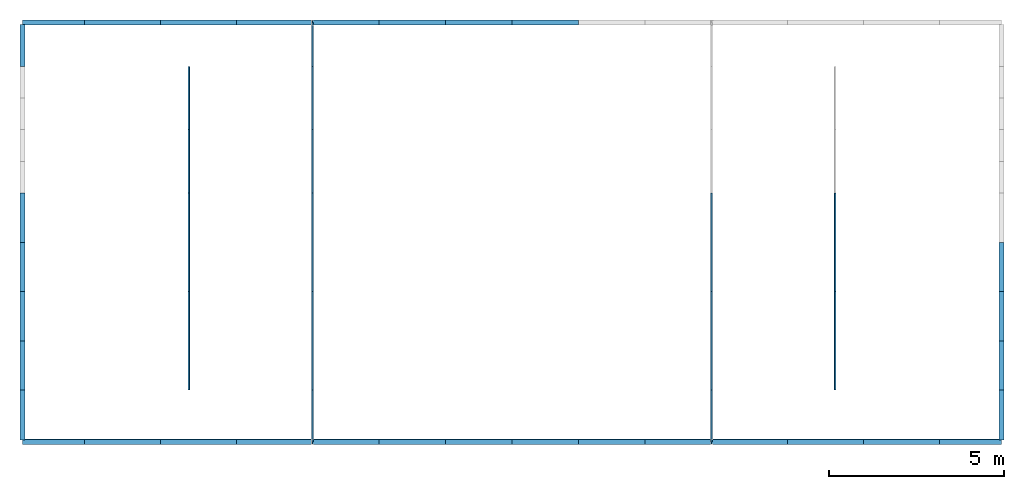
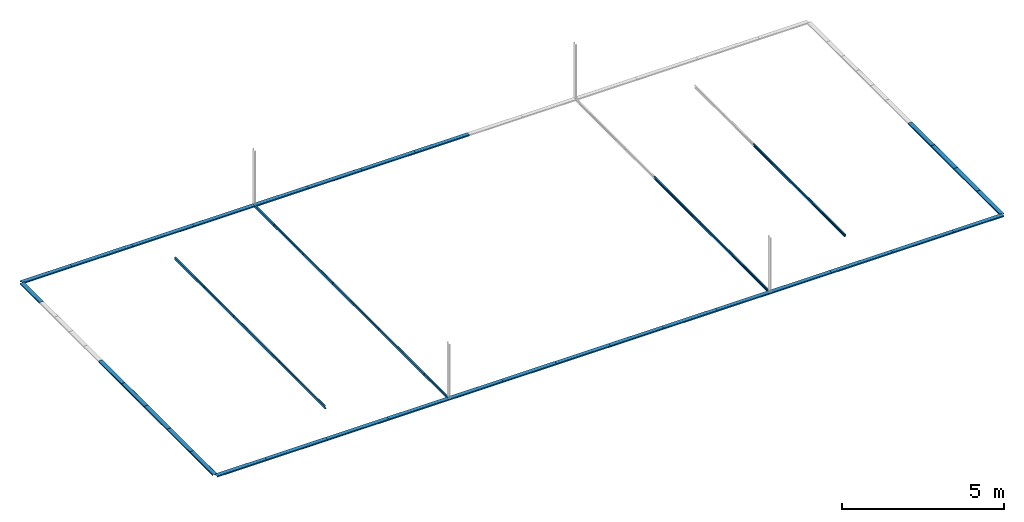
# One storey, part 3 of 4: 47 beams.
"""IFC4 building model written with IfcOpenShell, lengths in metres."""

from ifc_helpers import new_model, si_unit, derived_unit, frame, origin_with_axes, origin_2d_with_axis, place, context, project, spatial, c_section, extrude, material, material_profile, profile_set, profile_usage, element, save


model = new_model("IFC4")

# Units and contexts
model_context = context("Model", 3, world=origin_with_axes())
ifc_project = project(units=[si_unit("LENGTHUNIT", "METRE"), si_unit("AREAUNIT", "SQUARE_METRE"), si_unit("VOLUMEUNIT", "CUBIC_METRE"), derived_unit("SECTIONMODULUSUNIT", [(si_unit("LENGTHUNIT", "METRE"), 3)]), derived_unit("MOMENTOFINERTIAUNIT", [(si_unit("LENGTHUNIT", "METRE"), 4)]), si_unit("PLANEANGLEUNIT", "RADIAN"), si_unit("TIMEUNIT", "SECOND"), si_unit("THERMODYNAMICTEMPERATUREUNIT", "DEGREE_CELSIUS"), derived_unit("THERMALEXPANSIONCOEFFICIENTUNIT", [(si_unit("THERMODYNAMICTEMPERATUREUNIT", "DEGREE_CELSIUS"), -1)])], contexts=[model_context])

# Site, building, storey
site = spatial("IfcSite", under=ifc_project, CompositionType="ELEMENT")
building = spatial("IfcBuilding", under=site, Name="Building", CompositionType="ELEMENT")
storey = spatial("IfcBuildingStorey", under=building, Name="BASE LEVEL", CompositionType="ELEMENT", Elevation=7.8501)

# Beams
ifc_material = material(Name="SAE 1020")
ifc_material_profile_1 = material_profile(ifc_material, c_section(Depth=0.1, Width=0.05, WallThickness=0.003, Girth=0.017, InternalFilletRadius=0.003, at=origin_2d_with_axis()))
ifc_profile_set_1 = profile_set([ifc_material_profile_1])
ifc_profile_usage_1 = profile_usage(ifc_profile_set_1, cardinal=10)
beam_1_placement = place(None, frame((9.5343995, 8.75, 7.8501), z_axis=(3.3783784e-07, 1.0, -3.0405405e-05), x_axis=(0.9992562, 8.3491316e-07, 0.038562213)))
element("IfcBeam", 1, at=beam_1_placement, inside=storey, material=ifc_profile_usage_1, Name="1629", context=model_context, shape_type="SweptSolid", body=[
    extrude(c_section(Depth=0.1, Width=0.05, WallThickness=0.003, Girth=0.017, InternalFilletRadius=0.003, at=origin_2d_with_axis()), origin_with_axes(), (0.0, 0.0, 1.0), 1.48),
])
ifc_material_profile_2 = material_profile(ifc_material, c_section(Depth=0.1, Width=0.05, WallThickness=0.003, Girth=0.017, InternalFilletRadius=0.003, at=origin_2d_with_axis()))
ifc_profile_set_2 = profile_set([ifc_material_profile_2])
ifc_profile_usage_2 = profile_usage(ifc_profile_set_2, cardinal=10)
beam_2_placement = place(None, frame((9.5344, 10.23, 7.85), z_axis=(3.3783784e-07, 1.0, -3.0405405e-05), x_axis=(0.9992562, 8.3491316e-07, 0.038562213)))
element("IfcBeam", 2, at=beam_2_placement, inside=storey, material=ifc_profile_usage_2, Name="1630", context=model_context, shape_type="SweptSolid", body=[
    extrude(c_section(Depth=0.1, Width=0.05, WallThickness=0.003, Girth=0.017, InternalFilletRadius=0.003, at=origin_2d_with_axis()), origin_with_axes(), (0.0, 0.0, 1.0), 2.82),
])
ifc_material_profile_3 = material_profile(ifc_material, c_section(Depth=0.1, Width=0.05, WallThickness=0.003, Girth=0.017, InternalFilletRadius=0.003, at=origin_2d_with_axis()))
ifc_profile_set_3 = profile_set([ifc_material_profile_3])
ifc_profile_usage_3 = profile_usage(ifc_profile_set_3, cardinal=10)
beam_3_placement = place(None, frame((9.5344, 13.05, 7.85), z_axis=(3.3783784e-07, 1.0, -3.0405405e-05), x_axis=(0.9992562, 8.3491316e-07, 0.038562213)))
element("IfcBeam", 3, at=beam_3_placement, inside=storey, material=ifc_profile_usage_3, Name="1631", context=model_context, shape_type="SweptSolid", body=[
    extrude(c_section(Depth=0.1, Width=0.05, WallThickness=0.003, Girth=0.017, InternalFilletRadius=0.003, at=origin_2d_with_axis()), origin_with_axes(), (0.0, 0.0, 1.0), 2.82),
])
ifc_material_profile_4 = material_profile(ifc_material, c_section(Depth=0.1, Width=0.05, WallThickness=0.003, Girth=0.017, InternalFilletRadius=0.003, at=origin_2d_with_axis()))
ifc_profile_set_4 = profile_set([ifc_material_profile_4])
ifc_profile_usage_4 = profile_usage(ifc_profile_set_4, cardinal=10)
beam_4_placement = place(None, frame((9.5344, 15.87, 7.85), z_axis=(3.3783784e-07, 1.0, -3.0405405e-05), x_axis=(0.9992562, 8.3491316e-07, 0.038562213)))
element("IfcBeam", 4, at=beam_4_placement, inside=storey, material=ifc_profile_usage_4, Name="1632", context=model_context, shape_type="SweptSolid", body=[
    extrude(c_section(Depth=0.1, Width=0.05, WallThickness=0.003, Girth=0.017, InternalFilletRadius=0.003, at=origin_2d_with_axis()), origin_with_axes(), (0.0, 0.0, 1.0), 1.815),
])
ifc_material_profile_5 = material_profile(ifc_material, c_section(Depth=0.1, Width=0.05, WallThickness=0.003, Girth=0.017, InternalFilletRadius=0.003, at=origin_2d_with_axis()))
ifc_profile_set_5 = profile_set([ifc_material_profile_5])
ifc_profile_usage_5 = profile_usage(ifc_profile_set_5, cardinal=10)
beam_5_placement = place(None, frame((9.5344, 17.685, 7.85), z_axis=(3.3783784e-07, 1.0, -3.0405405e-05), x_axis=(0.9992562, 8.3491316e-07, 0.038562213)))
element("IfcBeam", 5, at=beam_5_placement, inside=storey, material=ifc_profile_usage_5, Name="1633", context=model_context, shape_type="SweptSolid", body=[
    extrude(c_section(Depth=0.1, Width=0.05, WallThickness=0.003, Girth=0.017, InternalFilletRadius=0.003, at=origin_2d_with_axis()), origin_with_axes(), (0.0, 0.0, 1.0), 1.815),
])
ifc_material_profile_6 = material_profile(ifc_material, c_section(Depth=0.1, Width=0.05, WallThickness=0.003, Girth=0.017, InternalFilletRadius=0.003, at=origin_2d_with_axis()))
ifc_profile_set_6 = profile_set([ifc_material_profile_6])
ifc_profile_usage_6 = profile_usage(ifc_profile_set_6, cardinal=10)
beam_6_placement = place(None, frame((9.5344, 19.5, 7.85), z_axis=(3.3783784e-07, 1.0, -3.0405405e-05), x_axis=(0.9992562, 8.3491316e-07, 0.038562213)))
element("IfcBeam", 6, at=beam_6_placement, inside=storey, material=ifc_profile_usage_6, Name="1634", context=model_context, shape_type="SweptSolid", body=[
    extrude(c_section(Depth=0.1, Width=0.05, WallThickness=0.003, Girth=0.017, InternalFilletRadius=0.003, at=origin_2d_with_axis()), origin_with_axes(), (0.0, 0.0, 1.0), 1.25),
])
ifc_material_profile_7 = material_profile(ifc_material, c_section(Depth=0.1, Width=0.05, WallThickness=0.003, Girth=0.017, InternalFilletRadius=0.003, at=origin_2d_with_axis()))
ifc_profile_set_7 = profile_set([ifc_material_profile_7])
ifc_profile_usage_7 = profile_usage(ifc_profile_set_7, cardinal=10)
beam_7_placement = place(None, frame((20.965601, 8.75, 7.8501), z_axis=(3.3783784e-07, 1.0, -3.0405405e-05), x_axis=(-0.9992562, 8.3491316e-07, 0.038562213)))
element("IfcBeam", 7, at=beam_7_placement, inside=storey, material=ifc_profile_usage_7, Name="1635", context=model_context, shape_type="SweptSolid", body=[
    extrude(c_section(Depth=0.1, Width=0.05, WallThickness=0.003, Girth=0.017, InternalFilletRadius=0.003, at=origin_2d_with_axis()), origin_with_axes(), (0.0, 0.0, 1.0), 1.48),
])
ifc_material_profile_8 = material_profile(ifc_material, c_section(Depth=0.1, Width=0.05, WallThickness=0.003, Girth=0.017, InternalFilletRadius=0.003, at=origin_2d_with_axis()))
ifc_profile_set_8 = profile_set([ifc_material_profile_8])
ifc_profile_usage_8 = profile_usage(ifc_profile_set_8, cardinal=10)
beam_8_placement = place(None, frame((20.9656, 10.23, 7.85), z_axis=(3.3783784e-07, 1.0, -3.0405405e-05), x_axis=(-0.9992562, 8.3491316e-07, 0.038562213)))
element("IfcBeam", 8, at=beam_8_placement, inside=storey, material=ifc_profile_usage_8, Name="1636", context=model_context, shape_type="SweptSolid", body=[
    extrude(c_section(Depth=0.1, Width=0.05, WallThickness=0.003, Girth=0.017, InternalFilletRadius=0.003, at=origin_2d_with_axis()), origin_with_axes(), (0.0, 0.0, 1.0), 2.82),
])
ifc_material_profile_9 = material_profile(ifc_material, c_section(Depth=0.1, Width=0.05, WallThickness=0.003, Girth=0.017, InternalFilletRadius=0.003, at=origin_2d_with_axis()))
ifc_profile_set_9 = profile_set([ifc_material_profile_9])
ifc_profile_usage_9 = profile_usage(ifc_profile_set_9, cardinal=10)
beam_9_placement = place(None, frame((20.9656, 13.05, 7.85), z_axis=(3.3783784e-07, 1.0, -3.0405405e-05), x_axis=(-0.9992562, 8.3491316e-07, 0.038562213)))
element("IfcBeam", 9, at=beam_9_placement, inside=storey, material=ifc_profile_usage_9, Name="1637", context=model_context, shape_type="SweptSolid", body=[
    extrude(c_section(Depth=0.1, Width=0.05, WallThickness=0.003, Girth=0.017, InternalFilletRadius=0.003, at=origin_2d_with_axis()), origin_with_axes(), (0.0, 0.0, 1.0), 2.82),
])
ifc_material_profile_10 = material_profile(ifc_material, c_section(Depth=0.15, Width=0.05, WallThickness=0.003, Girth=0.017, InternalFilletRadius=0.003, at=origin_2d_with_axis()))
ifc_profile_set_10 = profile_set([ifc_material_profile_10])
ifc_profile_usage_10 = profile_usage(ifc_profile_set_10, cardinal=10)
beam_10_placement = place(None, frame((1.2413995, 8.75, 7.85), z_axis=(1.0, 0.0, 0.0), x_axis=(-9.5775484e-06, 0.0, -1.0)))
element("IfcBeam", 10, at=beam_10_placement, inside=storey, material=ifc_profile_usage_10, Name="1661", context=model_context, shape_type="SweptSolid", body=[
    extrude(c_section(Depth=0.15, Width=0.05, WallThickness=0.003, Girth=0.017, InternalFilletRadius=0.003, at=origin_2d_with_axis()), origin_with_axes(), (0.0, 0.0, 1.0), 1.7749845),
])
ifc_material_profile_11 = material_profile(ifc_material, c_section(Depth=0.15, Width=0.05, WallThickness=0.003, Girth=0.017, InternalFilletRadius=0.003, at=origin_2d_with_axis()))
ifc_profile_set_11 = profile_set([ifc_material_profile_11])
ifc_profile_usage_11 = profile_usage(ifc_profile_set_11, cardinal=10)
beam_11_placement = place(None, frame((27.483584, 8.75, 7.849983), z_axis=(1.0, 0.0, 0.0), x_axis=(-9.5775484e-06, 0.0, -1.0)))
element("IfcBeam", 11, at=beam_11_placement, inside=storey, material=ifc_profile_usage_11, Name="1666", context=model_context, shape_type="SweptSolid", body=[
    extrude(c_section(Depth=0.15, Width=0.05, WallThickness=0.003, Girth=0.017, InternalFilletRadius=0.003, at=origin_2d_with_axis()), origin_with_axes(), (0.0, 0.0, 1.0), 1.7750155),
])
ifc_material_profile_12 = material_profile(ifc_material, c_section(Depth=0.15, Width=0.05, WallThickness=0.003, Girth=0.017, InternalFilletRadius=0.003, at=origin_2d_with_axis()))
ifc_profile_set_12 = profile_set([ifc_material_profile_12])
ifc_profile_usage_12 = profile_usage(ifc_profile_set_12, cardinal=10)
beam_12_placement = place(None, frame((3.0164, 20.75, 7.849983), z_axis=(-1.0, 0.0, -9.5774675e-06), x_axis=(-9.5775484e-06, 0.0, -1.0)))
element("IfcBeam", 12, at=beam_12_placement, inside=storey, material=ifc_profile_usage_12, Name="1672", context=model_context, shape_type="SweptSolid", body=[
    extrude(c_section(Depth=0.15, Width=0.05, WallThickness=0.003, Girth=0.017, InternalFilletRadius=0.003, at=origin_2d_with_axis()), origin_with_axes(), (0.0, 0.0, 1.0), 1.7750005),
])
ifc_material_profile_13 = material_profile(ifc_material, c_section(Depth=0.15, Width=0.05, WallThickness=0.003, Girth=0.017, InternalFilletRadius=0.003, at=origin_2d_with_axis()))
ifc_profile_set_13 = profile_set([ifc_material_profile_13])
ifc_profile_usage_13 = profile_usage(ifc_profile_set_13, cardinal=10)
beam_13_placement = place(None, frame((17.1552, 20.750011, 7.8500333), z_axis=(-1.0, 0.0, -9.5774675e-06), x_axis=(-9.5775484e-06, 0.0, -1.0)))
element("IfcBeam", 13, at=beam_13_placement, inside=storey, material=ifc_profile_usage_13, Name="1899", context=model_context, shape_type="SweptSolid", body=[
    extrude(c_section(Depth=0.15, Width=0.05, WallThickness=0.003, Girth=0.017, InternalFilletRadius=0.003, at=origin_2d_with_axis()), origin_with_axes(), (0.0, 0.0, 1.0), 1.9052002),
])
ifc_material_profile_14 = material_profile(ifc_material, c_section(Depth=0.15, Width=0.05, WallThickness=0.003, Girth=0.017, InternalFilletRadius=0.003, at=origin_2d_with_axis()))
ifc_profile_set_14 = profile_set([ifc_material_profile_14])
ifc_profile_usage_14 = profile_usage(ifc_profile_set_14, cardinal=10)
beam_14_placement = place(None, frame((15.25, 20.750016, 7.85), z_axis=(-1.0, 0.0, -9.5774675e-06), x_axis=(-9.5775484e-06, 0.0, -1.0)))
element("IfcBeam", 14, at=beam_14_placement, inside=storey, material=ifc_profile_usage_14, Name="1900", context=model_context, shape_type="SweptSolid", body=[
    extrude(c_section(Depth=0.15, Width=0.05, WallThickness=0.003, Girth=0.017, InternalFilletRadius=0.003, at=origin_2d_with_axis()), origin_with_axes(), (0.0, 0.0, 1.0), 1.9052002),
])
ifc_material_profile_15 = material_profile(ifc_material, c_section(Depth=0.15, Width=0.05, WallThickness=0.003, Girth=0.017, InternalFilletRadius=0.003, at=origin_2d_with_axis()))
ifc_profile_set_15 = profile_set([ifc_material_profile_15])
ifc_profile_usage_15 = profile_usage(ifc_profile_set_15, cardinal=10)
beam_15_placement = place(None, frame((13.3448, 20.750011, 7.8500333), z_axis=(-1.0, 0.0, -9.5774675e-06), x_axis=(-9.5775484e-06, 0.0, -1.0)))
element("IfcBeam", 15, at=beam_15_placement, inside=storey, material=ifc_profile_usage_15, Name="1901", context=model_context, shape_type="SweptSolid", body=[
    extrude(c_section(Depth=0.15, Width=0.05, WallThickness=0.003, Girth=0.017, InternalFilletRadius=0.003, at=origin_2d_with_axis()), origin_with_axes(), (0.0, 0.0, 1.0), 1.9052002),
])
ifc_material_profile_16 = material_profile(ifc_material, c_section(Depth=0.15, Width=0.05, WallThickness=0.003, Girth=0.017, InternalFilletRadius=0.003, at=origin_2d_with_axis()))
ifc_profile_set_16 = profile_set([ifc_material_profile_16])
ifc_profile_usage_16 = profile_usage(ifc_profile_set_16, cardinal=10)
beam_16_placement = place(None, frame((11.4396, 20.750005, 7.8500667), z_axis=(-1.0, 0.0, -9.5774675e-06), x_axis=(-9.5775484e-06, 0.0, -1.0)))
element("IfcBeam", 16, at=beam_16_placement, inside=storey, material=ifc_profile_usage_16, Name="1902", context=model_context, shape_type="SweptSolid", body=[
    extrude(c_section(Depth=0.15, Width=0.05, WallThickness=0.003, Girth=0.017, InternalFilletRadius=0.003, at=origin_2d_with_axis()), origin_with_axes(), (0.0, 0.0, 1.0), 1.9052002),
])
ifc_material_profile_17 = material_profile(ifc_material, c_section(Depth=0.15, Width=0.05, WallThickness=0.003, Girth=0.017, InternalFilletRadius=0.003, at=origin_2d_with_axis()))
ifc_profile_set_17 = profile_set([ifc_material_profile_17])
ifc_profile_usage_17 = profile_usage(ifc_profile_set_17, cardinal=10)
beam_17_placement = place(None, frame((9.5343995, 20.75, 7.8501), z_axis=(-1.0, 0.0, -9.5774675e-06), x_axis=(-9.5775484e-06, 0.0, -1.0)))
element("IfcBeam", 17, at=beam_17_placement, inside=storey, material=ifc_profile_usage_17, Name="1903", context=model_context, shape_type="SweptSolid", body=[
    extrude(c_section(Depth=0.15, Width=0.05, WallThickness=0.003, Girth=0.017, InternalFilletRadius=0.003, at=origin_2d_with_axis()), origin_with_axes(), (0.0, 0.0, 1.0), 2.1726665),
])
ifc_material_profile_18 = material_profile(ifc_material, c_section(Depth=0.15, Width=0.05, WallThickness=0.003, Girth=0.017, InternalFilletRadius=0.003, at=origin_2d_with_axis()))
ifc_profile_set_18 = profile_set([ifc_material_profile_18])
ifc_profile_usage_18 = profile_usage(ifc_profile_set_18, cardinal=10)
beam_18_placement = place(None, frame((7.361733, 20.75, 7.850061), z_axis=(-1.0, 0.0, -9.5774675e-06), x_axis=(-9.5775484e-06, 0.0, -1.0)))
element("IfcBeam", 18, at=beam_18_placement, inside=storey, material=ifc_profile_usage_18, Name="1904", context=model_context, shape_type="SweptSolid", body=[
    extrude(c_section(Depth=0.15, Width=0.05, WallThickness=0.003, Girth=0.017, InternalFilletRadius=0.003, at=origin_2d_with_axis()), origin_with_axes(), (0.0, 0.0, 1.0), 2.1726665),
])
ifc_material_profile_19 = material_profile(ifc_material, c_section(Depth=0.15, Width=0.05, WallThickness=0.003, Girth=0.017, InternalFilletRadius=0.003, at=origin_2d_with_axis()))
ifc_profile_set_19 = profile_set([ifc_material_profile_19])
ifc_profile_usage_19 = profile_usage(ifc_profile_set_19, cardinal=10)
beam_19_placement = place(None, frame((5.1890665, 20.75, 7.850022), z_axis=(-1.0, 0.0, -9.5774675e-06), x_axis=(-9.5775484e-06, 0.0, -1.0)))
element("IfcBeam", 19, at=beam_19_placement, inside=storey, material=ifc_profile_usage_19, Name="1905", context=model_context, shape_type="SweptSolid", body=[
    extrude(c_section(Depth=0.15, Width=0.05, WallThickness=0.003, Girth=0.017, InternalFilletRadius=0.003, at=origin_2d_with_axis()), origin_with_axes(), (0.0, 0.0, 1.0), 2.1726665),
])
ifc_material_profile_20 = material_profile(ifc_material, c_section(Depth=0.15, Width=0.05, WallThickness=0.003, Girth=0.017, InternalFilletRadius=0.003, at=origin_2d_with_axis()))
ifc_profile_set_20 = profile_set([ifc_material_profile_20])
ifc_profile_usage_20 = profile_usage(ifc_profile_set_20, cardinal=10)
beam_20_placement = place(None, frame((1.2414, 10.23, 7.85), z_axis=(3.3783784e-07, 1.0, -3.0405405e-05), x_axis=(-9.5775484e-06, 0.0, -1.0)))
element("IfcBeam", 20, at=beam_20_placement, inside=storey, material=ifc_profile_usage_20, Name="1998", context=model_context, shape_type="SweptSolid", body=[
    extrude(c_section(Depth=0.15, Width=0.05, WallThickness=0.003, Girth=0.017, InternalFilletRadius=0.003, at=origin_2d_with_axis()), origin_with_axes(), (0.0, 0.0, 1.0), 1.41),
])
ifc_material_profile_21 = material_profile(ifc_material, c_section(Depth=0.15, Width=0.05, WallThickness=0.003, Girth=0.017, InternalFilletRadius=0.003, at=origin_2d_with_axis()))
ifc_profile_set_21 = profile_set([ifc_material_profile_21])
ifc_profile_usage_21 = profile_usage(ifc_profile_set_21, cardinal=10)
beam_21_placement = place(None, frame((1.2414, 11.64, 7.85), z_axis=(3.3783784e-07, 1.0, -3.0405405e-05), x_axis=(-9.5775484e-06, 0.0, -1.0)))
element("IfcBeam", 21, at=beam_21_placement, inside=storey, material=ifc_profile_usage_21, Name="1999", context=model_context, shape_type="SweptSolid", body=[
    extrude(c_section(Depth=0.15, Width=0.05, WallThickness=0.003, Girth=0.017, InternalFilletRadius=0.003, at=origin_2d_with_axis()), origin_with_axes(), (0.0, 0.0, 1.0), 1.41),
])
ifc_material_profile_22 = material_profile(ifc_material, c_section(Depth=0.15, Width=0.05, WallThickness=0.003, Girth=0.017, InternalFilletRadius=0.003, at=origin_2d_with_axis()))
ifc_profile_set_22 = profile_set([ifc_material_profile_22])
ifc_profile_usage_22 = profile_usage(ifc_profile_set_22, cardinal=10)
beam_22_placement = place(None, frame((1.2414, 13.05, 7.85), z_axis=(3.3783784e-07, 1.0, -3.0405405e-05), x_axis=(-9.5775484e-06, 0.0, -1.0)))
element("IfcBeam", 22, at=beam_22_placement, inside=storey, material=ifc_profile_usage_22, Name="2000", context=model_context, shape_type="SweptSolid", body=[
    extrude(c_section(Depth=0.15, Width=0.05, WallThickness=0.003, Girth=0.017, InternalFilletRadius=0.003, at=origin_2d_with_axis()), origin_with_axes(), (0.0, 0.0, 1.0), 1.41),
])
ifc_material_profile_23 = material_profile(ifc_material, c_section(Depth=0.15, Width=0.05, WallThickness=0.003, Girth=0.017, InternalFilletRadius=0.003, at=origin_2d_with_axis()))
ifc_profile_set_23 = profile_set([ifc_material_profile_23])
ifc_profile_usage_23 = profile_usage(ifc_profile_set_23, cardinal=10)
beam_23_placement = place(None, frame((1.2414, 14.46, 7.85), z_axis=(3.3783784e-07, 1.0, -3.0405405e-05), x_axis=(-9.5775484e-06, 0.0, -1.0)))
element("IfcBeam", 23, at=beam_23_placement, inside=storey, material=ifc_profile_usage_23, Name="2001", context=model_context, shape_type="SweptSolid", body=[
    extrude(c_section(Depth=0.15, Width=0.05, WallThickness=0.003, Girth=0.017, InternalFilletRadius=0.003, at=origin_2d_with_axis()), origin_with_axes(), (0.0, 0.0, 1.0), 1.41),
])
ifc_material_profile_24 = material_profile(ifc_material, c_section(Depth=0.15, Width=0.05, WallThickness=0.003, Girth=0.017, InternalFilletRadius=0.003, at=origin_2d_with_axis()))
ifc_profile_set_24 = profile_set([ifc_material_profile_24])
ifc_profile_usage_24 = profile_usage(ifc_profile_set_24, cardinal=10)
beam_24_placement = place(None, frame((29.2586, 10.23, 7.85), z_axis=(3.3783784e-07, 1.0, -3.0405405e-05), x_axis=(-9.5775484e-06, 0.0, -1.0)))
element("IfcBeam", 24, at=beam_24_placement, inside=storey, material=ifc_profile_usage_24, Name="2014", context=model_context, shape_type="SweptSolid", body=[
    extrude(c_section(Depth=0.15, Width=0.05, WallThickness=0.003, Girth=0.017, InternalFilletRadius=0.003, at=origin_2d_with_axis()), origin_with_axes(), (0.0, 0.0, 1.0), 1.41),
])
ifc_material_profile_25 = material_profile(ifc_material, c_section(Depth=0.15, Width=0.05, WallThickness=0.003, Girth=0.017, InternalFilletRadius=0.003, at=origin_2d_with_axis()))
ifc_profile_set_25 = profile_set([ifc_material_profile_25])
ifc_profile_usage_25 = profile_usage(ifc_profile_set_25, cardinal=10)
beam_25_placement = place(None, frame((29.2586, 11.64, 7.85), z_axis=(3.3783784e-07, 1.0, -3.0405405e-05), x_axis=(-9.5775484e-06, 0.0, -1.0)))
element("IfcBeam", 25, at=beam_25_placement, inside=storey, material=ifc_profile_usage_25, Name="2015", context=model_context, shape_type="SweptSolid", body=[
    extrude(c_section(Depth=0.15, Width=0.05, WallThickness=0.003, Girth=0.017, InternalFilletRadius=0.003, at=origin_2d_with_axis()), origin_with_axes(), (0.0, 0.0, 1.0), 1.41),
])
ifc_material_profile_26 = material_profile(ifc_material, c_section(Depth=0.15, Width=0.05, WallThickness=0.003, Girth=0.017, InternalFilletRadius=0.003, at=origin_2d_with_axis()))
ifc_profile_set_26 = profile_set([ifc_material_profile_26])
ifc_profile_usage_26 = profile_usage(ifc_profile_set_26, cardinal=10)
beam_26_placement = place(None, frame((29.2586, 13.05, 7.85), z_axis=(3.3783784e-07, 1.0, -3.0405405e-05), x_axis=(-9.5775484e-06, 0.0, -1.0)))
element("IfcBeam", 26, at=beam_26_placement, inside=storey, material=ifc_profile_usage_26, Name="2016", context=model_context, shape_type="SweptSolid", body=[
    extrude(c_section(Depth=0.15, Width=0.05, WallThickness=0.003, Girth=0.017, InternalFilletRadius=0.003, at=origin_2d_with_axis()), origin_with_axes(), (0.0, 0.0, 1.0), 1.41),
])
ifc_material_profile_27 = material_profile(ifc_material, c_section(Depth=0.15, Width=0.05, WallThickness=0.003, Girth=0.017, InternalFilletRadius=0.003, at=origin_2d_with_axis()))
ifc_profile_set_27 = profile_set([ifc_material_profile_27])
ifc_profile_usage_27 = profile_usage(ifc_profile_set_27, cardinal=10)
beam_27_placement = place(None, frame((3.016384, 8.75, 7.849983), z_axis=(1.0, 0.0, 0.0), x_axis=(-9.5775484e-06, 0.0, -1.0)))
element("IfcBeam", 27, at=beam_27_placement, inside=storey, material=ifc_profile_usage_27, Name="2040", context=model_context, shape_type="SweptSolid", body=[
    extrude(c_section(Depth=0.15, Width=0.05, WallThickness=0.003, Girth=0.017, InternalFilletRadius=0.003, at=origin_2d_with_axis()), origin_with_axes(), (0.0, 0.0, 1.0), 2.1726825),
])
ifc_material_profile_28 = material_profile(ifc_material, c_section(Depth=0.15, Width=0.05, WallThickness=0.003, Girth=0.017, InternalFilletRadius=0.003, at=origin_2d_with_axis()))
ifc_profile_set_28 = profile_set([ifc_material_profile_28])
ifc_profile_usage_28 = profile_usage(ifc_profile_set_28, cardinal=10)
beam_28_placement = place(None, frame((5.1890665, 8.75, 7.850022), z_axis=(1.0, 0.0, 0.0), x_axis=(-9.5775484e-06, 0.0, -1.0)))
element("IfcBeam", 28, at=beam_28_placement, inside=storey, material=ifc_profile_usage_28, Name="2041", context=model_context, shape_type="SweptSolid", body=[
    extrude(c_section(Depth=0.15, Width=0.05, WallThickness=0.003, Girth=0.017, InternalFilletRadius=0.003, at=origin_2d_with_axis()), origin_with_axes(), (0.0, 0.0, 1.0), 2.1726665),
])
ifc_material_profile_29 = material_profile(ifc_material, c_section(Depth=0.15, Width=0.05, WallThickness=0.003, Girth=0.017, InternalFilletRadius=0.003, at=origin_2d_with_axis()))
ifc_profile_set_29 = profile_set([ifc_material_profile_29])
ifc_profile_usage_29 = profile_usage(ifc_profile_set_29, cardinal=10)
beam_29_placement = place(None, frame((7.361733, 8.75, 7.850061), z_axis=(1.0, 0.0, 0.0), x_axis=(-9.5775484e-06, 0.0, -1.0)))
element("IfcBeam", 29, at=beam_29_placement, inside=storey, material=ifc_profile_usage_29, Name="2042", context=model_context, shape_type="SweptSolid", body=[
    extrude(c_section(Depth=0.15, Width=0.05, WallThickness=0.003, Girth=0.017, InternalFilletRadius=0.003, at=origin_2d_with_axis()), origin_with_axes(), (0.0, 0.0, 1.0), 2.1726665),
])
ifc_material_profile_30 = material_profile(ifc_material, c_section(Depth=0.15, Width=0.05, WallThickness=0.003, Girth=0.017, InternalFilletRadius=0.003, at=origin_2d_with_axis()))
ifc_profile_set_30 = profile_set([ifc_material_profile_30])
ifc_profile_usage_30 = profile_usage(ifc_profile_set_30, cardinal=10)
beam_30_placement = place(None, frame((9.5343995, 8.75, 7.8501), z_axis=(1.0, 0.0, 0.0), x_axis=(-9.5775484e-06, 0.0, -1.0)))
element("IfcBeam", 30, at=beam_30_placement, inside=storey, material=ifc_profile_usage_30, Name="2043", context=model_context, shape_type="SweptSolid", body=[
    extrude(c_section(Depth=0.15, Width=0.05, WallThickness=0.003, Girth=0.017, InternalFilletRadius=0.003, at=origin_2d_with_axis()), origin_with_axes(), (0.0, 0.0, 1.0), 1.9052002),
])
ifc_material_profile_31 = material_profile(ifc_material, c_section(Depth=0.15, Width=0.05, WallThickness=0.003, Girth=0.017, InternalFilletRadius=0.003, at=origin_2d_with_axis()))
ifc_profile_set_31 = profile_set([ifc_material_profile_31])
ifc_profile_usage_31 = profile_usage(ifc_profile_set_31, cardinal=10)
beam_31_placement = place(None, frame((11.4396, 8.7500053, 7.8500667), z_axis=(1.0, 0.0, 0.0), x_axis=(-9.5775484e-06, 0.0, -1.0)))
element("IfcBeam", 31, at=beam_31_placement, inside=storey, material=ifc_profile_usage_31, Name="2044", context=model_context, shape_type="SweptSolid", body=[
    extrude(c_section(Depth=0.15, Width=0.05, WallThickness=0.003, Girth=0.017, InternalFilletRadius=0.003, at=origin_2d_with_axis()), origin_with_axes(), (0.0, 0.0, 1.0), 1.9052002),
])
ifc_material_profile_32 = material_profile(ifc_material, c_section(Depth=0.15, Width=0.05, WallThickness=0.003, Girth=0.017, InternalFilletRadius=0.003, at=origin_2d_with_axis()))
ifc_profile_set_32 = profile_set([ifc_material_profile_32])
ifc_profile_usage_32 = profile_usage(ifc_profile_set_32, cardinal=10)
beam_32_placement = place(None, frame((13.3448, 8.7500107, 7.8500333), z_axis=(1.0, 0.0, 0.0), x_axis=(-9.5775484e-06, 0.0, -1.0)))
element("IfcBeam", 32, at=beam_32_placement, inside=storey, material=ifc_profile_usage_32, Name="2045", context=model_context, shape_type="SweptSolid", body=[
    extrude(c_section(Depth=0.15, Width=0.05, WallThickness=0.003, Girth=0.017, InternalFilletRadius=0.003, at=origin_2d_with_axis()), origin_with_axes(), (0.0, 0.0, 1.0), 1.9051842),
])
ifc_material_profile_33 = material_profile(ifc_material, c_section(Depth=0.15, Width=0.05, WallThickness=0.003, Girth=0.017, InternalFilletRadius=0.003, at=origin_2d_with_axis()))
ifc_profile_set_33 = profile_set([ifc_material_profile_33])
ifc_profile_usage_33 = profile_usage(ifc_profile_set_33, cardinal=10)
beam_33_placement = place(None, frame((15.249984, 8.750016, 7.85), z_axis=(1.0, 0.0, 0.0), x_axis=(-9.5775484e-06, 0.0, -1.0)))
element("IfcBeam", 33, at=beam_33_placement, inside=storey, material=ifc_profile_usage_33, Name="2046", context=model_context, shape_type="SweptSolid", body=[
    extrude(c_section(Depth=0.15, Width=0.05, WallThickness=0.003, Girth=0.017, InternalFilletRadius=0.003, at=origin_2d_with_axis()), origin_with_axes(), (0.0, 0.0, 1.0), 1.9052162),
])
ifc_material_profile_34 = material_profile(ifc_material, c_section(Depth=0.15, Width=0.05, WallThickness=0.003, Girth=0.017, InternalFilletRadius=0.003, at=origin_2d_with_axis()))
ifc_profile_set_34 = profile_set([ifc_material_profile_34])
ifc_profile_usage_34 = profile_usage(ifc_profile_set_34, cardinal=10)
beam_34_placement = place(None, frame((17.1552, 8.7500107, 7.8500333), z_axis=(1.0, 0.0, 0.0), x_axis=(-9.5775484e-06, 0.0, -1.0)))
element("IfcBeam", 34, at=beam_34_placement, inside=storey, material=ifc_profile_usage_34, Name="2047", context=model_context, shape_type="SweptSolid", body=[
    extrude(c_section(Depth=0.15, Width=0.05, WallThickness=0.003, Girth=0.017, InternalFilletRadius=0.003, at=origin_2d_with_axis()), origin_with_axes(), (0.0, 0.0, 1.0), 1.9052002),
])
ifc_material_profile_35 = material_profile(ifc_material, c_section(Depth=0.15, Width=0.05, WallThickness=0.003, Girth=0.017, InternalFilletRadius=0.003, at=origin_2d_with_axis()))
ifc_profile_set_35 = profile_set([ifc_material_profile_35])
ifc_profile_usage_35 = profile_usage(ifc_profile_set_35, cardinal=10)
beam_35_placement = place(None, frame((19.0604, 8.7500053, 7.8500667), z_axis=(1.0, 0.0, 0.0), x_axis=(-9.5775484e-06, 0.0, -1.0)))
element("IfcBeam", 35, at=beam_35_placement, inside=storey, material=ifc_profile_usage_35, Name="2048", context=model_context, shape_type="SweptSolid", body=[
    extrude(c_section(Depth=0.15, Width=0.05, WallThickness=0.003, Girth=0.017, InternalFilletRadius=0.003, at=origin_2d_with_axis()), origin_with_axes(), (0.0, 0.0, 1.0), 1.9052002),
])
ifc_material_profile_36 = material_profile(ifc_material, c_section(Depth=0.15, Width=0.05, WallThickness=0.003, Girth=0.017, InternalFilletRadius=0.003, at=origin_2d_with_axis()))
ifc_profile_set_36 = profile_set([ifc_material_profile_36])
ifc_profile_usage_36 = profile_usage(ifc_profile_set_36, cardinal=10)
beam_36_placement = place(None, frame((20.965601, 8.75, 7.8501), z_axis=(1.0, 0.0, 0.0), x_axis=(-9.5775484e-06, 0.0, -1.0)))
element("IfcBeam", 36, at=beam_36_placement, inside=storey, material=ifc_profile_usage_36, Name="2049", context=model_context, shape_type="SweptSolid", body=[
    extrude(c_section(Depth=0.15, Width=0.05, WallThickness=0.003, Girth=0.017, InternalFilletRadius=0.003, at=origin_2d_with_axis()), origin_with_axes(), (0.0, 0.0, 1.0), 2.1726665),
])
ifc_material_profile_37 = material_profile(ifc_material, c_section(Depth=0.15, Width=0.05, WallThickness=0.003, Girth=0.017, InternalFilletRadius=0.003, at=origin_2d_with_axis()))
ifc_profile_set_37 = profile_set([ifc_material_profile_37])
ifc_profile_usage_37 = profile_usage(ifc_profile_set_37, cardinal=10)
beam_37_placement = place(None, frame((23.138267, 8.75, 7.850061), z_axis=(1.0, 0.0, 0.0), x_axis=(-9.5775484e-06, 0.0, -1.0)))
element("IfcBeam", 37, at=beam_37_placement, inside=storey, material=ifc_profile_usage_37, Name="2050", context=model_context, shape_type="SweptSolid", body=[
    extrude(c_section(Depth=0.15, Width=0.05, WallThickness=0.003, Girth=0.017, InternalFilletRadius=0.003, at=origin_2d_with_axis()), origin_with_axes(), (0.0, 0.0, 1.0), 2.1726665),
])
ifc_material_profile_38 = material_profile(ifc_material, c_section(Depth=0.15, Width=0.05, WallThickness=0.003, Girth=0.017, InternalFilletRadius=0.003, at=origin_2d_with_axis()))
ifc_profile_set_38 = profile_set([ifc_material_profile_38])
ifc_profile_usage_38 = profile_usage(ifc_profile_set_38, cardinal=10)
beam_38_placement = place(None, frame((25.310934, 8.75, 7.850022), z_axis=(1.0, 0.0, 0.0), x_axis=(-9.5775484e-06, 0.0, -1.0)))
element("IfcBeam", 38, at=beam_38_placement, inside=storey, material=ifc_profile_usage_38, Name="2051", context=model_context, shape_type="SweptSolid", body=[
    extrude(c_section(Depth=0.15, Width=0.05, WallThickness=0.003, Girth=0.017, InternalFilletRadius=0.003, at=origin_2d_with_axis()), origin_with_axes(), (0.0, 0.0, 1.0), 2.1726505),
])
ifc_material_profile_39 = material_profile(ifc_material, c_section(Depth=0.1, Width=0.05, WallThickness=0.003, Girth=0.017, InternalFilletRadius=0.003, at=origin_2d_with_axis()))
ifc_profile_set_39 = profile_set([ifc_material_profile_39])
ifc_profile_usage_39 = profile_usage(ifc_profile_set_39, cardinal=10)
beam_39_placement = place(None, frame((24.499996, 10.23, 7.85), z_axis=(3.3783784e-07, 1.0, -3.0405405e-05), x_axis=(-0.9992562, 8.3491316e-07, 0.038562213)))
element("IfcBeam", 39, at=beam_39_placement, inside=storey, material=ifc_profile_usage_39, Name="903", context=model_context, shape_type="SweptSolid", body=[
    extrude(c_section(Depth=0.1, Width=0.05, WallThickness=0.003, Girth=0.017, InternalFilletRadius=0.003, at=origin_2d_with_axis()), origin_with_axes(), (0.0, 0.0, 1.0), 2.82),
])
ifc_material_profile_40 = material_profile(ifc_material, c_section(Depth=0.1, Width=0.05, WallThickness=0.003, Girth=0.017, InternalFilletRadius=0.003, at=origin_2d_with_axis()))
ifc_profile_set_40 = profile_set([ifc_material_profile_40])
ifc_profile_usage_40 = profile_usage(ifc_profile_set_40, cardinal=10)
beam_40_placement = place(None, frame((24.499996, 13.05, 7.85), z_axis=(3.3783784e-07, 1.0, -3.0405405e-05), x_axis=(-0.9992562, 8.3491316e-07, 0.038562213)))
element("IfcBeam", 40, at=beam_40_placement, inside=storey, material=ifc_profile_usage_40, Name="904", context=model_context, shape_type="SweptSolid", body=[
    extrude(c_section(Depth=0.1, Width=0.05, WallThickness=0.003, Girth=0.017, InternalFilletRadius=0.003, at=origin_2d_with_axis()), origin_with_axes(), (0.0, 0.0, 1.0), 2.82),
])
ifc_material_profile_41 = material_profile(ifc_material, c_section(Depth=0.1, Width=0.05, WallThickness=0.003, Girth=0.017, InternalFilletRadius=0.003, at=origin_2d_with_axis()))
ifc_profile_set_41 = profile_set([ifc_material_profile_41])
ifc_profile_usage_41 = profile_usage(ifc_profile_set_41, cardinal=10)
beam_41_placement = place(None, frame((6.0000045, 10.23, 7.85), z_axis=(3.3783784e-07, 1.0, -3.0405405e-05), x_axis=(0.9992562, 8.3491316e-07, 0.038562213)))
element("IfcBeam", 41, at=beam_41_placement, inside=storey, material=ifc_profile_usage_41, Name="907", context=model_context, shape_type="SweptSolid", body=[
    extrude(c_section(Depth=0.1, Width=0.05, WallThickness=0.003, Girth=0.017, InternalFilletRadius=0.003, at=origin_2d_with_axis()), origin_with_axes(), (0.0, 0.0, 1.0), 2.82),
])
ifc_material_profile_42 = material_profile(ifc_material, c_section(Depth=0.1, Width=0.05, WallThickness=0.003, Girth=0.017, InternalFilletRadius=0.003, at=origin_2d_with_axis()))
ifc_profile_set_42 = profile_set([ifc_material_profile_42])
ifc_profile_usage_42 = profile_usage(ifc_profile_set_42, cardinal=10)
beam_42_placement = place(None, frame((6.0000045, 13.05, 7.85), z_axis=(3.3783784e-07, 1.0, -3.0405405e-05), x_axis=(0.9992562, 8.3491316e-07, 0.038562213)))
element("IfcBeam", 42, at=beam_42_placement, inside=storey, material=ifc_profile_usage_42, Name="909", context=model_context, shape_type="SweptSolid", body=[
    extrude(c_section(Depth=0.1, Width=0.05, WallThickness=0.003, Girth=0.017, InternalFilletRadius=0.003, at=origin_2d_with_axis()), origin_with_axes(), (0.0, 0.0, 1.0), 2.82),
])
ifc_material_profile_43 = material_profile(ifc_material, c_section(Depth=0.1, Width=0.05, WallThickness=0.003, Girth=0.017, InternalFilletRadius=0.003, at=origin_2d_with_axis()))
ifc_profile_set_43 = profile_set([ifc_material_profile_43])
ifc_profile_usage_43 = profile_usage(ifc_profile_set_43, cardinal=10)
beam_43_placement = place(None, frame((6.0000045, 15.87, 7.85), z_axis=(3.3783784e-07, 1.0, -3.0405405e-05), x_axis=(0.9992562, 8.3491316e-07, 0.038562213)))
element("IfcBeam", 43, at=beam_43_placement, inside=storey, material=ifc_profile_usage_43, Name="913", context=model_context, shape_type="SweptSolid", body=[
    extrude(c_section(Depth=0.1, Width=0.05, WallThickness=0.003, Girth=0.017, InternalFilletRadius=0.003, at=origin_2d_with_axis()), origin_with_axes(), (0.0, 0.0, 1.0), 1.815),
])
ifc_material_profile_44 = material_profile(ifc_material, c_section(Depth=0.1, Width=0.05, WallThickness=0.003, Girth=0.017, InternalFilletRadius=0.003, at=origin_2d_with_axis()))
ifc_profile_set_44 = profile_set([ifc_material_profile_44])
ifc_profile_usage_44 = profile_usage(ifc_profile_set_44, cardinal=10)
beam_44_placement = place(None, frame((6.0000045, 17.685, 7.85), z_axis=(3.3783784e-07, 1.0, -3.0405405e-05), x_axis=(0.9992562, 8.3491316e-07, 0.038562213)))
element("IfcBeam", 44, at=beam_44_placement, inside=storey, material=ifc_profile_usage_44, Name="915", context=model_context, shape_type="SweptSolid", body=[
    extrude(c_section(Depth=0.1, Width=0.05, WallThickness=0.003, Girth=0.017, InternalFilletRadius=0.003, at=origin_2d_with_axis()), origin_with_axes(), (0.0, 0.0, 1.0), 1.815),
])
ifc_material_profile_45 = material_profile(ifc_material, c_section(Depth=0.15, Width=0.05, WallThickness=0.003, Girth=0.017, InternalFilletRadius=0.003, at=origin_2d_with_axis()))
ifc_profile_set_45 = profile_set([ifc_material_profile_45])
ifc_profile_usage_45 = profile_usage(ifc_profile_set_45, cardinal=10)
beam_45_placement = place(None, frame((1.2413995, 8.8, 7.85), z_axis=(3.3783784e-07, 1.0, -3.0405405e-05), x_axis=(-9.5775484e-06, 0.0, -1.0)))
element("IfcBeam", 45, at=beam_45_placement, inside=storey, material=ifc_profile_usage_45, Name="2140", context=model_context, shape_type="SweptSolid", body=[
    extrude(c_section(Depth=0.15, Width=0.05, WallThickness=0.003, Girth=0.017, InternalFilletRadius=0.003, at=origin_2d_with_axis()), origin_with_axes(), (0.0, 0.0, 1.0), 1.43),
])
ifc_material_profile_46 = material_profile(ifc_material, c_section(Depth=0.15, Width=0.05, WallThickness=0.003, Girth=0.017, InternalFilletRadius=0.003, at=origin_2d_with_axis()))
ifc_profile_set_46 = profile_set([ifc_material_profile_46])
ifc_profile_usage_46 = profile_usage(ifc_profile_set_46, cardinal=10)
beam_46_placement = place(None, frame((1.2414, 19.5, 7.85), z_axis=(3.3783784e-07, 1.0, -3.0405405e-05), x_axis=(-9.5775484e-06, 0.0, -1.0)))
element("IfcBeam", 46, at=beam_46_placement, inside=storey, material=ifc_profile_usage_46, Name="2141", context=model_context, shape_type="SweptSolid", body=[
    extrude(c_section(Depth=0.15, Width=0.05, WallThickness=0.003, Girth=0.017, InternalFilletRadius=0.003, at=origin_2d_with_axis()), origin_with_axes(), (0.0, 0.0, 1.0), 1.2),
])
ifc_material_profile_47 = material_profile(ifc_material, c_section(Depth=0.15, Width=0.05, WallThickness=0.003, Girth=0.017, InternalFilletRadius=0.003, at=origin_2d_with_axis()))
ifc_profile_set_47 = profile_set([ifc_material_profile_47])
ifc_profile_usage_47 = profile_usage(ifc_profile_set_47, cardinal=10)
beam_47_placement = place(None, frame((29.258599, 8.8, 7.85), z_axis=(3.3783784e-07, 1.0, -3.0405405e-05), x_axis=(-9.5775484e-06, 0.0, -1.0)))
element("IfcBeam", 47, at=beam_47_placement, inside=storey, material=ifc_profile_usage_47, Name="2158", context=model_context, shape_type="SweptSolid", body=[
    extrude(c_section(Depth=0.15, Width=0.05, WallThickness=0.003, Girth=0.017, InternalFilletRadius=0.003, at=origin_2d_with_axis()), origin_with_axes(), (0.0, 0.0, 1.0), 1.43),
])

save(model, "model.ifc")
